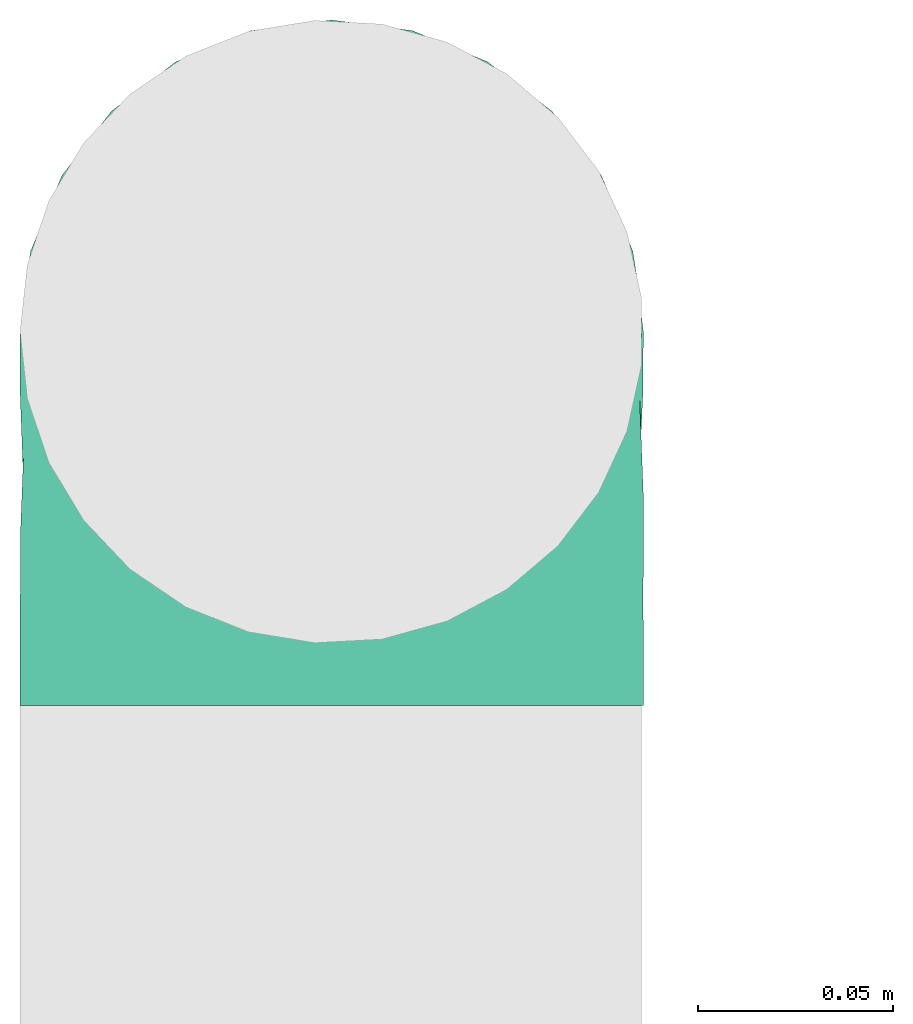
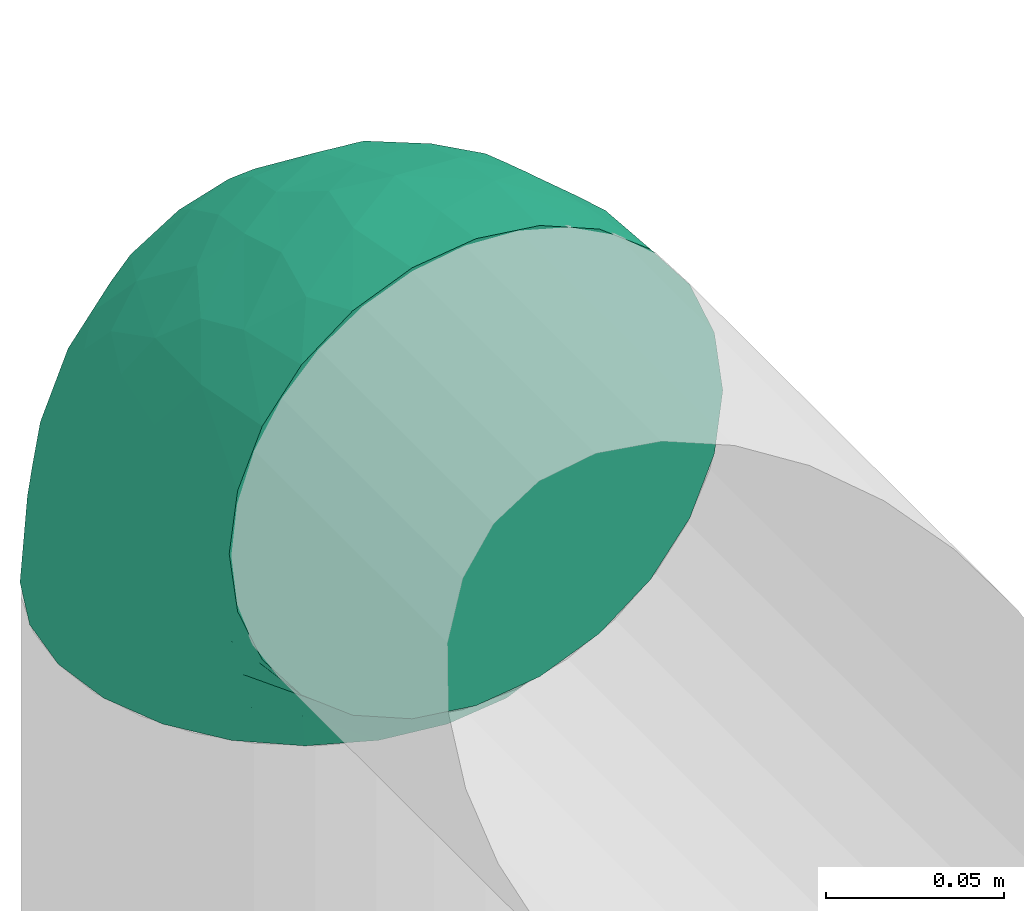
# One storey, part 10 of 12: 1 flow fitting.
"""IFC2X3 building model written with IfcOpenShell, lengths in millimetres."""

import ifcopenshell
import ifcopenshell.guid

model = None  # the IFC model being written
_history = None  # IfcOwnerHistory: only IFC2X3 demands one
_inside = {}  # id of a spatial element -> (the spatial element, [elements in it])
_under = {}  # id of a project, library or spatial element -> (it, [spatial elements below it])
_declared = {}  # id of a project -> (the project, [libraries it declares])
_typed = {}  # id of a type object -> (the type object, [elements of that type])
_made_of = {}  # id of a material, layer set ... -> (it, [elements and type objects made of it])


def new_model(schema):
    """Start an empty IFC model of exactly this schema.

    Asked for "IFC4X3", IfcOpenShell would pick the latest addendum, in which some entities
    have other attributes; the version numbers below select the first issue.
    IFC2X3 requires an IfcOwnerHistory on every rooted entity: one is made here for all.
    """
    global model, _history
    if schema == "IFC4X3":
        model = ifcopenshell.file(schema_version=(4, 3, 0, 0))
    else:
        model = ifcopenshell.file(schema=schema)
    _inside.clear()
    _under.clear()
    _declared.clear()
    _typed.clear()
    _made_of.clear()
    _history = None
    if model.schema == "IFC2X3":
        org = make("IfcOrganization", Name="unknown")
        user = make(
            "IfcPersonAndOrganization",
            ThePerson=make("IfcPerson", FamilyName="unknown"),
            TheOrganization=org,
        )
        app = make(
            "IfcApplication",
            ApplicationDeveloper=org,
            Version="unknown",
            ApplicationFullName="unknown",
            ApplicationIdentifier="unknown",
        )
        _history = make(
            "IfcOwnerHistory",
            OwningUser=user,
            OwningApplication=app,
            ChangeAction="ADDED",
            CreationDate=0,
        )
    return model


def make(cls, **values):
    """One entity of the class cls with the attributes given. An attribute that is None is left unset."""
    return model.create_entity(
        cls, **{name: value for name, value in values.items() if value is not None}
    )


def entity(cls, *values):
    """Any entity or typed value of the class cls, its attributes in the order of the schema. None: left unset."""
    e = model.create_entity(cls)
    for i, value in enumerate(values):
        if value is not None:
            e[i] = value
    return e


def rooted(cls, **values):
    """An entity with a GlobalId (a new one), such as an element, a storey or a relation."""
    return make(cls, GlobalId=ifcopenshell.guid.new(), OwnerHistory=_history, **values)


def si_unit(unit_type, name, prefix=None):
    """IfcSIUnit, for example si_unit("LENGTHUNIT", "METRE", prefix="MILLI")."""
    return make("IfcSIUnit", UnitType=unit_type, Prefix=prefix, Name=name)


def converted_unit(unit_type, name, factor, base, dimensions=None, offset=None):
    """IfcConversionBasedUnit, such as the inch: factor (a typed value) times the base unit."""
    return make(
        "IfcConversionBasedUnit"
        if offset is None
        else "IfcConversionBasedUnitWithOffset",
        ConversionOffset=offset,
        Dimensions=None
        if dimensions is None
        else entity("IfcDimensionalExponents", *dimensions),
        UnitType=unit_type,
        Name=name,
        ConversionFactor=make(
            "IfcMeasureWithUnit", ValueComponent=factor, UnitComponent=base
        ),
    )


def derived_unit(unit_type, elements):
    """IfcDerivedUnit: a product of units, each with its exponent."""
    return make(
        "IfcDerivedUnit",
        Elements=[
            make("IfcDerivedUnitElement", Unit=unit, Exponent=power)
            for unit, power in elements
        ],
        UnitType=unit_type,
    )


def assignment(units):
    """IfcUnitAssignment: the units of a project."""
    return None if units is None else make("IfcUnitAssignment", Units=units)


def point(xyz):
    """IfcCartesianPoint."""
    return None if xyz is None else make("IfcCartesianPoint", Coordinates=xyz)


def direction(xyz):
    """IfcDirection."""
    return None if xyz is None else make("IfcDirection", DirectionRatios=xyz)


def frame(location, z_axis=None, x_axis=None):
    """IfcAxis2Placement3D, a coordinate frame: its origin and axes. An axis left out is left unset."""
    return make(
        "IfcAxis2Placement3D",
        Location=point(location),
        Axis=direction(z_axis),
        RefDirection=direction(x_axis),
    )


def origin():
    """The frame at (0, 0, 0) with its axes left unset."""
    return frame((0.0, 0.0, 0.0))


def place(relative_to, where):
    """IfcLocalPlacement: puts the frame where relative to a parent placement (None: the world)."""
    return make(
        "IfcLocalPlacement", PlacementRelTo=relative_to, RelativePlacement=where
    )


def context(
    kind, dimensions, precision=None, world=None, true_north=None, identifier=None
):
    """IfcGeometricRepresentationContext, for example the 3D "Model" context."""
    return make(
        "IfcGeometricRepresentationContext",
        ContextIdentifier=identifier,
        ContextType=kind,
        CoordinateSpaceDimension=dimensions,
        Precision=precision,
        WorldCoordinateSystem=world,
        TrueNorth=true_north,
    )


def subcontext(parent, identifier, kind, view, scale=None):
    """IfcGeometricRepresentationSubContext, for example "Body" below "Model"."""
    return make(
        "IfcGeometricRepresentationSubContext",
        ContextIdentifier=identifier,
        ContextType=kind,
        ParentContext=parent,
        TargetScale=scale,
        TargetView=view,
    )


def project(units=None, contexts=None):
    """IfcProject with its units and contexts."""
    return rooted(
        "IfcProject",
        Name="project",
        RepresentationContexts=contexts,
        UnitsInContext=assignment(units),
    )


def spatial(cls, under=None, at=None, **own):
    """A site, building, storey or space (cls), placed at a placement, below another one or the project."""
    s = rooted(cls, ObjectPlacement=at, **own)
    if under is not None:
        _under.setdefault(under.id(), (under, []))[1].append(s)
    return s


def faces_of(points, faces, orient=None, outer=None):
    """IfcFace entities. A face is a list of loops; a loop is a list of indices into points, from 0.

    orient and outer hold one flag for each loop. By default every Orientation is true, the
    first loop of a face is its IfcFaceOuterBound and the others are IfcFaceBound.
    """
    made = []
    for i, loops in enumerate(faces):
        bounds = []
        for j, loop in enumerate(loops):
            is_outer = j == 0 if outer is None else outer[i][j]
            bounds.append(
                make(
                    "IfcFaceOuterBound" if is_outer else "IfcFaceBound",
                    Bound=make("IfcPolyLoop", Polygon=[points[k] for k in loop]),
                    Orientation=True if orient is None else orient[i][j],
                )
            )
        made.append(make("IfcFace", Bounds=bounds))
    return made


def faceted_brep(points, faces, orient=None, outer=None, voids=None):
    """IfcFacetedBrep: a solid bounded by flat faces; with voids (closed shells), ...WithVoids."""
    shared = [point(p) for p in points]
    hull = make("IfcClosedShell", CfsFaces=faces_of(shared, faces, orient, outer))
    if voids is None:
        return make("IfcFacetedBrep", Outer=hull)
    return make(
        "IfcFacetedBrepWithVoids",
        Outer=hull,
        Voids=[
            make(cls, CfsFaces=faces_of(shared, fs, o, b)) for cls, fs, o, b in voids
        ],
    )


def shape(context_of_items, identifier, shape_type, items):
    """IfcShapeRepresentation: the items that make up one representation, for example the "Body"."""
    return make(
        "IfcShapeRepresentation",
        ContextOfItems=context_of_items,
        RepresentationIdentifier=identifier,
        RepresentationType=shape_type,
        Items=items,
    )


def source(mapping_origin, context_of_items, identifier, shape_type, items):
    """IfcRepresentationMap: a shape defined once, which mapped items show again and again."""
    return make(
        "IfcRepresentationMap",
        MappingOrigin=mapping_origin,
        MappedRepresentation=shape(context_of_items, identifier, shape_type, items),
    )


def transform(
    local_origin,
    x_axis=None,
    y_axis=None,
    z_axis=None,
    scale=None,
    scale2=None,
    scale3=None,
    uniform=True,
):
    """IfcCartesianTransformationOperator3D, or its non-uniform kind. x_axis, y_axis, z_axis: its Axis1, 2, 3."""
    if uniform:
        return make(
            "IfcCartesianTransformationOperator3D",
            Axis1=direction(x_axis),
            Axis2=direction(y_axis),
            LocalOrigin=point(local_origin),
            Scale=scale,
            Axis3=direction(z_axis),
        )
    return make(
        "IfcCartesianTransformationOperator3DnonUniform",
        Axis1=direction(x_axis),
        Axis2=direction(y_axis),
        LocalOrigin=point(local_origin),
        Scale=scale,
        Axis3=direction(z_axis),
        Scale2=scale2,
        Scale3=scale3,
    )


def mapped(mapping_source, mapping_target):
    """IfcMappedItem: shows the shape of a source again, moved by a transform."""
    return make(
        "IfcMappedItem", MappingSource=mapping_source, MappingTarget=mapping_target
    )


def made_of(thing, what):
    """Note that an element or type object is made of a material, layer set ...; save() writes the relation."""
    if what is not None:
        _made_of.setdefault(what.id(), (what, []))[1].append(thing)
    return thing


def type_object(cls, material=None, **own):
    """A type object (cls), such as IfcWallType, which elements share."""
    return made_of(rooted(cls, **own), material)


def type_shapes(of_type, sources):
    """Give a type object the sources (RepresentationMaps) that its elements show as mapped items."""
    of_type.RepresentationMaps = sources


def element(
    cls,
    number,
    at=None,
    inside=None,
    cuts=None,
    type_object=None,
    material=None,
    context=None,
    identifier="Body",
    shape_type=None,
    held_by="IfcProductDefinitionShape",
    body=None,
    shapes=None,
    **own,
):
    """One element of the class cls, such as IfcWall. Its Tag is "e" and its number.

    at: its placement. inside: the storey or other place that contains it. cuts: it is an
    opening in that element (IfcRelVoidsElement). A single representation is given by context,
    identifier, shape_type and body (its items); several are given by shapes. held_by: the class
    of the entity that holds the representations. save() writes the other relations.
    """
    e = rooted(cls, Tag="e%d" % number, ObjectPlacement=at, **own)
    if body is not None:
        shapes = [shape(context, identifier, shape_type, body)]
    if shapes is not None:
        e.Representation = make(held_by, Representations=shapes)
    if inside is not None:
        _inside.setdefault(inside.id(), (inside, []))[1].append(e)
    if cuts is not None:
        rooted(
            "IfcRelVoidsElement", RelatingBuildingElement=cuts, RelatedOpeningElement=e
        )
    if type_object is not None:
        _typed.setdefault(type_object.id(), (type_object, []))[1].append(e)
    return made_of(e, material)


def aggregate(whole, parts):
    """IfcRelAggregates: a whole, such as a stair, and the parts it consists of."""
    return rooted("IfcRelAggregates", RelatingObject=whole, RelatedObjects=parts)


def save(model, path):
    """Write the relations noted so far, then the file.

    IfcRelAggregates (storeys below a building ...), IfcRelContainedInSpatialStructure (elements
    in a storey), IfcRelDefinesByType, IfcRelAssociatesMaterial and IfcRelDeclares: one each for
    every whole, place, type object, material and project.
    """
    for whole, parts in _under.values():
        aggregate(whole, parts)
    for where, things in _inside.values():
        rooted(
            "IfcRelContainedInSpatialStructure",
            RelatedElements=things,
            RelatingStructure=where,
        )
    for kind, things in _typed.values():
        rooted("IfcRelDefinesByType", RelatedObjects=things, RelatingType=kind)
    for what, things in _made_of.values():
        rooted("IfcRelAssociatesMaterial", RelatedObjects=things, RelatingMaterial=what)
    for by, libraries in _declared.values():
        rooted("IfcRelDeclares", RelatingContext=by, RelatedDefinitions=libraries)
    model.write(path)


model = new_model("IFC2X3")

# Units and contexts
model_context = context("Model", 3, precision=0.01, world=origin(), true_north=direction((6.12303176911189e-17, 1.0)))
body_context = subcontext(model_context, "Body", "Model", "MODEL_VIEW")
ifc_project = project(units=[si_unit("LENGTHUNIT", "METRE", prefix="MILLI"), si_unit("AREAUNIT", "SQUARE_METRE"), si_unit("VOLUMEUNIT", "CUBIC_METRE"), converted_unit("PLANEANGLEUNIT", "DEGREE", entity("IfcRatioMeasure", 0.0174532925199433), si_unit("PLANEANGLEUNIT", "RADIAN"), dimensions=[0, 0, 0, 0, 0, 0, 0]), si_unit("MASSUNIT", "GRAM", prefix="KILO"), derived_unit("MASSDENSITYUNIT", [(si_unit("MASSUNIT", "GRAM", prefix="KILO"), 1), (si_unit("LENGTHUNIT", "METRE"), -3)]), si_unit("TIMEUNIT", "SECOND"), si_unit("FREQUENCYUNIT", "HERTZ"), si_unit("THERMODYNAMICTEMPERATUREUNIT", "DEGREE_CELSIUS"), derived_unit("THERMALTRANSMITTANCEUNIT", [(si_unit("MASSUNIT", "GRAM", prefix="KILO"), 1), (si_unit("THERMODYNAMICTEMPERATUREUNIT", "KELVIN"), -1), (si_unit("TIMEUNIT", "SECOND"), -3)]), derived_unit("VOLUMETRICFLOWRATEUNIT", [(si_unit("LENGTHUNIT", "METRE"), 3), (si_unit("TIMEUNIT", "SECOND"), -1)]), si_unit("ELECTRICCURRENTUNIT", "AMPERE"), si_unit("ELECTRICVOLTAGEUNIT", "VOLT"), si_unit("POWERUNIT", "WATT"), si_unit("FORCEUNIT", "NEWTON", prefix="KILO"), si_unit("ILLUMINANCEUNIT", "LUX"), si_unit("LUMINOUSFLUXUNIT", "LUMEN"), si_unit("LUMINOUSINTENSITYUNIT", "CANDELA"), derived_unit("USERDEFINED", [(si_unit("MASSUNIT", "GRAM", prefix="KILO"), -1), (si_unit("LENGTHUNIT", "METRE"), -2), (si_unit("TIMEUNIT", "SECOND"), 3), (si_unit("LUMINOUSFLUXUNIT", "LUMEN"), 1)]), derived_unit("LINEARVELOCITYUNIT", [(si_unit("LENGTHUNIT", "METRE"), 1), (si_unit("TIMEUNIT", "SECOND"), -1)]), si_unit("PRESSUREUNIT", "PASCAL"), derived_unit("USERDEFINED", [(si_unit("LENGTHUNIT", "METRE"), -2), (si_unit("MASSUNIT", "GRAM", prefix="KILO"), 1), (si_unit("TIMEUNIT", "SECOND"), -2)])], contexts=[model_context])

# Site, building, storey
site_placement = place(None, origin())
site = spatial("IfcSite", under=ifc_project, at=site_placement, CompositionType="ELEMENT")
building_placement = place(site_placement, origin())
building = spatial("IfcBuilding", under=site, at=building_placement, CompositionType="ELEMENT")
storey_placement = place(building_placement, frame((0.0, 0.0, 4000.0)))
storey = spatial("IfcBuildingStorey", under=building, at=storey_placement, Name="01 Level", CompositionType="ELEMENT", Elevation=4000.0)

# Flow fitting
duct_fitting_type = type_object("IfcDuctFittingType", Name="Air_Elbow short_Circ", PredefinedType="NOTDEFINED")
shared_shape = source(origin(), body_context, "Body", "Brep", [
    faceted_brep([(-96.0, 0.0, -80.0), (-96.0, -20.7055236082018, -77.2740661031254), (-96.0, -40.0, -69.2820323027551), (-96.0, -56.5685424949239, -56.5685424949238), (-96.0, -69.2820323027551, -40.0), (-96.0, -77.2740661031255, -20.7055236082016), (-96.0, -80.0, 0.0), (-96.0, -77.2740661031253, 20.7055236082021), (-96.0, -69.2820323027549, 40.0), (-96.0, -56.5685424949235, 56.5685424949241), (-96.0, -40.0, 69.2820323027553), (-96.0, -30.3527618041005, 73.2780492029404), (-96.0, -20.7055236082013, 77.2740661031256), (-96.0, 0.0, 80.0), (-96.0, 20.705523608202, 77.2740661031254), (-96.0, 40.0, 69.2820323027549), (-96.0, 56.568542494924, 56.5685424949236), (-96.0, 69.2820323027553, 40.0), (-96.0, 77.2740661031256, 20.7055236082014), (-96.0, 80.0, 0.0), (-96.0, 77.2740661031254, -20.7055236082019), (-96.0, 69.282032302755, -40.0), (-96.0, 56.5685424949237, -56.5685424949239), (-96.0, 40.0, -69.2820323027552), (-96.0, 20.7055236082015, -77.2740661031255), (0.0, -96.0, -80.0), (20.7055236082025, -96.0, -77.2740661031255), (40.0, -96.0, -69.2820323027552), (56.5685424949246, -96.0, -56.5685424949239), (69.2820323027559, -96.0, -40.0), (77.2740661031264, -96.0, -20.7055236082019), (80.0, -96.0, 0.0), (77.2740661031265, -96.0, 20.7055236082014), (69.2820323027562, -96.0, 40.0), (56.5685424949249, -96.0, 56.5685424949236), (40.0, -96.0, 69.2820323027549), (20.7055236082029, -96.0, 77.2740661031254), (0.0, -96.0, 80.0), (-20.7055236082004, -96.0, 77.2740661031256), (-40.0, -96.0, 69.2820323027553), (-56.5685424949226, -96.0, 56.5685424949241), (-69.2820323027539, -96.0, 40.0), (-77.2740661031244, -96.0, 20.7055236082021), (-80.0, -96.0, 0.0), (-77.2740661031245, -96.0, -20.7055236082016), (-69.2820323027542, -96.0, -40.0), (-56.5685424949229, -96.0, -56.5685424949238), (-40.0, -96.0, -69.2820323027551), (-30.3527618041, -96.0, -73.2780492029402), (-20.7055236082008, -96.0, -77.2740661031254), (-69.6571465232348, -6.28172173912476, 79.9611058756859), (-66.7862289407348, 74.1387210661139, 22.9795507758541), (-78.4902527850466, 65.2482264041437, 44.9229732355936), (-55.1380888291464, 64.4450584799279, 39.5029426177976), (-75.1250134759213, -46.3506195730757, 68.0011973810265), (-79.9123689128389, -22.4151301859584, 77.2816866630488), (-67.1316735243184, 51.7530432423058, 58.5204707533666), (-62.9760666105318, 34.5362195419601, 70.0448030595901), (-46.2820694578435, 43.7397705581167, 60.5188244193914), (-76.2276812833835, 77.3969248578635, 0.0), (-50.4478480619551, 74.0029454268759, 0.0), (-6.30632028234235, -70.6421404093778, 79.9513108199466), (-27.189372084162, -68.980536479128, 76.8941402015288), (-29.8609237116382, 28.9682345099716, 65.8760199345924), (-47.7584488981354, 13.6212410427434, 76.3881123659885), (43.7397637815864, -46.2820598522933, 60.518827155348), (51.7530435574228, -67.1316742002235, 58.5204705859065), (57.6005967886466, -33.4719572927763, 39.0176496769077), (-74.2591571701267, 14.3645886695287, 78.2829835259588), (7.8513563843086, 42.4938374080907, 21.3232874317503), (23.3846344985257, 27.9066135199674, 24.7887114209846), (28.4507934888335, 28.4507934888321, 0.0), (-84.190871651952, -70.905997349447, 41.7100461919055), (10.21505333872, 32.0754161621096, 38.020212353501), (-0.0180155578363953, 25.9284255475521, 53.836744023285), (24.7272484782103, 2.06889411058577, 53.4325037134459), (-41.7574890626937, -15.123136403511, 79.988056483004), (-64.5619855594544, -27.52018553659, 77.2892967298799), (-8.0, 56.420471066061, 0.0), (-29.2239240309769, 65.2117082464685, 0.0), (-24.5336756868846, 60.9669573051438, 23.5003835585885), (-16.4008295437786, -51.3122057461681, 79.8609584412684), (-84.6862915010143, -84.6862915010152, 0.0), (-83.0529092063249, -83.0529092103045, 19.0855009657076), (-82.4185651555764, -62.2587017800419, 53.3339952483838), (-46.3022193149449, -75.902750025661, 67.8445262622594), (-9.5260688639158, 47.7232209131232, 35.4187162694583), (74.1387213421635, -66.7862279048973, 22.9795492840646), (34.536215572589, -62.976064096567, 70.0448048426748), (14.3645870599314, -74.259154996167, 78.2829837700474), (65.2482273833467, -78.4902510979302, 44.9229715327465), (-25.6317751341749, -1.2640655514879, 76.9124052095498), (-12.3935655196116, -25.4017250572252, 78.8652642576962), (60.9669574479924, -24.5336725945725, 23.5003789659965), (64.4450597015273, -55.1380839274934, 39.5029384026545), (69.8186739706361, -42.5625104806759, 16.7980672722629), (77.3969247188647, -76.2276802275763, 0.0), (74.002945426877, -50.4478480619565, 0.0), (-52.4774893100348, -53.0631556360015, 72.0041598972686), (-66.5995156060253, -66.5995146556305, 58.6370817132137), (-76.4857465466113, -78.9385356944492, 38.5867538667356), (-62.2587016209511, -82.4185645906685, 53.3339956492136), (13.6212369177471, -47.7584433090926, 76.3881128402526), (28.9682276847195, -29.8609133580269, 65.8760207540895), (-6.49930484510329, 53.7890406240985, 15.4645725223014), (-33.731289034344, -40.0214486160993, 79.0537019298314), (46.1336936566893, -26.2441492635858, 50.151541479116), (50.0005984633279, -1.26038287501495, 17.5763945268078), (56.4204710660622, -8.0, 0.0), (42.4356322774479, 10.225396744416, 0.0), (-45.4536887619888, 68.8356359385787, 23.6914879663761), (-33.3493864711472, 57.4572215948989, 39.1720709545353), (35.9683398342664, 11.0724559744972, 30.5391080332169), (-26.2441652621668, 46.1336984778153, 50.1515448602929), (36.6749123583047, 17.5982116941791, 14.5644188861001), (65.2117082464696, -29.2239240309784, 0.0), (49.5968730216335, -12.1440064858134, 34.8325942562253), (-47.1533280807863, -29.0746114834461, 78.9127210009486), (-0.981722938535007, -51.3162880079176, 79.4920802366619), (-1.95170750213435, -1.95169859379814, 70.9272590604952), (12.4951682569875, -20.0804783439543, 71.2292489374933), (13.0725391330592, -1.13338064801589, 63.5790506070627), (-1.93327092594732, 13.4823821925323, 63.7412032706882), (-18.9298205951927, 13.0048872663631, 70.6672094580024), (10.2253967444173, 42.4356322774466, 0.0), (-68.9805369123341, -27.1893702897943, -76.8941406355589), (-46.3506180288022, -75.1250185023919, -68.0011970559212), (-27.5201921618733, -64.5619784506715, -77.2892959136582), (-22.4151342180024, -79.9123577737124, -77.2816862456941), (-74.2591561090454, 14.364589592643, -78.2829832920378), (-66.78622820047, 74.1387209331735, -22.9795507950237), (-42.5625109127564, 69.8186736490614, -16.7980693145318), (-70.6421421271429, -6.30631801763141, -79.9513108797024), (-1.2640784754681, -25.6317655571971, -76.9124065444174), (-15.1231475192353, -41.7574898106582, -79.9880566497423), (-25.401718902627, -12.3935649209934, -78.8652635038296), (-82.4185656924104, -62.258701559575, -53.3339952529289), (-66.5995166501766, -66.5995137008527, -58.6370816545605), (-78.9385361639639, -76.4857467527193, -38.5867530236755), (53.7890400497189, -6.49930371043273, -15.4645720709197), (60.9669567069012, -24.5336743104721, -23.5003834743896), (-24.5336751436549, 60.9669572920351, -23.5003828649414), (-55.1380878256228, 64.4450583029017, -39.5029424837467), (-46.2820677406335, 43.7397707662098, -60.5188237522514), (-26.2441631797834, 46.1336980827234, -50.1515441608816), (-29.8609212227281, 28.9682353164184, -65.8760186412515), (74.1387206827049, -66.7862275406284, -22.9795512458422), (-40.0214489824224, -33.7312845774564, -79.0537024061946), (-78.4902524468744, 65.2482264004152, -44.9229731872606), (-75.902751427461, -46.3022186029078, -67.8445263463497), (-70.9059970555813, -84.1908706304995, -41.7100473389448), (-62.9760652707231, 34.536220162299, -70.044802546446), (-67.1316724627346, 51.7530434014037, -58.5204704180807), (-33.4719630839568, 57.6005950429912, -39.0176564793206), (-51.3122062597491, -16.4008248291117, -79.8609586691244), (-6.28171714934502, -69.65712797409, -79.9611061760713), (51.7530427306645, -67.1316703492073, -58.5204706539109), (-83.0529092397056, -83.0529091932979, -19.0855009185769), (68.8356349913375, -45.45368838847, -23.6914905340598), (-62.258701383479, -82.4185638376438, -53.3339962098694), (34.53621889603, -62.9760621802168, -70.0448028055675), (-1.26038544288408, 50.0005998980998, -17.5763953891677), (14.3645887716112, -74.2591526334116, -78.2829833202131), (13.6212385978137, -47.75844096294, -76.3881120677864), (65.2482261461557, -78.4902526871683, -44.9229735979605), (32.0754071702863, 10.2150656939878, -38.0202105656364), (25.9284207554091, -0.0180077987247146, -53.8367428868672), (2.068884460932, 24.7272580800759, -53.4325021883878), (47.723215348146, -9.52606271707191, -35.4187195087105), (42.4938359077841, 7.8513587520169, -21.3232866357369), (27.9066094773716, 23.3846413342612, -24.7887058003424), (28.9682309044935, -29.8609168472814, -65.8760199178674), (64.4450577206072, -55.1380878066959, -39.5029434692504), (-53.063150048133, -52.4774843719861, -72.0041634993662), (43.7397687897612, -46.2820667462245, -60.5188250739327), (-47.7584463040963, 13.6212426330217, -76.3881115880261), (57.4572201066452, -33.3493827160302, -39.1720708806551), (11.0724494499294, 35.9683446288498, -30.5391089716619), (46.1336964749623, -26.2441642243134, -50.1515465265606), (17.5982028158329, 36.6749194460897, -14.5644209948051), (-12.1440097531109, 49.5968729214507, -34.8325978072281), (-29.0746218055845, -47.1533256390974, -78.912719851915), (-51.3162911259858, -0.981717610547608, -79.4920798409907), (-1.95170139871169, -1.95169735730944, -70.9272563527003), (-20.0804667507281, 12.4951842966219, -71.2292388196267), (-1.13337124471279, 13.072540998247, -63.5790448193562), (13.4823844636247, -1.93327501577089, -63.7412039856557), (13.0048800657406, -18.9298191902065, -70.6672121474654)], [[[0, 1, 2, 3, 4, 5, 6, 7, 8, 9, 10, 11, 12, 13, 14, 15, 16, 17, 18, 19, 20, 21, 22, 23, 24]], [[25, 26, 27, 28, 29, 30, 31, 32, 33, 34, 35, 36, 37, 38, 39, 40, 41, 42, 43, 44, 45, 46, 47, 48, 49]], [[50, 13, 12]], [[51, 52, 53]], [[10, 54, 55]], [[56, 57, 58]], [[59, 51, 60]], [[61, 62, 38]], [[63, 57, 64]], [[65, 66, 67]], [[17, 16, 52]], [[15, 57, 56]], [[14, 13, 68]], [[69, 70, 71]], [[8, 7, 72]], [[68, 64, 57]], [[73, 74, 75]], [[76, 50, 77]], [[57, 15, 14]], [[9, 54, 10]], [[55, 12, 11, 10]], [[78, 79, 80]], [[62, 61, 81]], [[82, 83, 6]], [[63, 58, 57]], [[83, 7, 6]], [[8, 72, 84]], [[56, 16, 15]], [[84, 9, 8]], [[62, 85, 39]], [[86, 74, 73]], [[59, 18, 51]], [[18, 17, 51]], [[32, 87, 33]], [[35, 34, 66]], [[36, 88, 89]], [[90, 34, 33]], [[88, 36, 35]], [[91, 76, 92]], [[90, 33, 87]], [[93, 94, 95]], [[35, 66, 88]], [[32, 96, 87]], [[85, 40, 39]], [[87, 97, 95]], [[98, 99, 85]], [[41, 100, 42]], [[42, 100, 83]], [[101, 99, 100]], [[102, 88, 103]], [[43, 83, 82]], [[104, 78, 80]], [[38, 62, 39]], [[98, 85, 62]], [[92, 76, 105]], [[65, 106, 103]], [[101, 41, 40]], [[37, 61, 38]], [[107, 108, 109]], [[51, 53, 110]], [[37, 36, 89]], [[79, 110, 80]], [[110, 79, 60]], [[111, 110, 53]], [[112, 70, 73]], [[113, 86, 111]], [[71, 114, 109]], [[75, 103, 106]], [[93, 95, 115]], [[37, 89, 61]], [[108, 93, 115]], [[67, 93, 116]], [[107, 116, 93]], [[13, 50, 68]], [[117, 76, 77]], [[98, 117, 77]], [[99, 54, 84]], [[40, 85, 101]], [[98, 54, 99]], [[105, 62, 81]], [[89, 118, 61]], [[88, 66, 65]], [[94, 66, 90]], [[16, 56, 52]], [[111, 53, 56]], [[76, 64, 50]], [[64, 76, 91]], [[119, 92, 120]], [[61, 118, 81]], [[120, 121, 119]], [[116, 112, 75]], [[121, 122, 119]], [[119, 122, 123]], [[113, 63, 74]], [[119, 123, 91]], [[86, 113, 74]], [[122, 121, 75]], [[54, 98, 77]], [[105, 98, 62]], [[59, 19, 18]], [[97, 87, 96]], [[32, 31, 96]], [[102, 89, 88]], [[14, 68, 57]], [[64, 68, 50]], [[41, 101, 100]], [[99, 101, 85]], [[9, 84, 54]], [[100, 99, 72]], [[81, 92, 105]], [[102, 92, 118]], [[81, 118, 92]], [[102, 118, 89]], [[84, 72, 99]], [[83, 100, 72]], [[72, 7, 83]], [[42, 83, 43]], [[17, 52, 51]], [[53, 52, 56]], [[34, 90, 66]], [[94, 90, 87]], [[55, 54, 77]], [[55, 50, 12]], [[55, 77, 50]], [[60, 51, 110]], [[80, 110, 111]], [[86, 104, 80]], [[58, 113, 111]], [[111, 86, 80]], [[73, 69, 86]], [[69, 73, 70]], [[112, 73, 75]], [[69, 124, 104]], [[108, 107, 93]], [[112, 114, 70]], [[93, 67, 94]], [[112, 107, 114]], [[70, 114, 71]], [[109, 114, 107]], [[106, 116, 75]], [[116, 107, 112]], [[94, 67, 66]], [[67, 116, 106]], [[115, 95, 97]], [[69, 104, 86]], [[78, 104, 124]], [[69, 71, 124]], [[87, 95, 94]], [[88, 65, 103]], [[106, 65, 67]], [[56, 58, 111]], [[113, 58, 63]], [[117, 105, 76]], [[105, 117, 98]], [[63, 64, 123]], [[119, 91, 92]], [[91, 123, 64]], [[74, 63, 122]], [[123, 122, 63]], [[74, 122, 75]], [[121, 103, 75]], [[103, 121, 120]], [[120, 102, 103]], [[102, 120, 92]], [[1, 125, 2]], [[126, 127, 128]], [[129, 0, 24]], [[130, 60, 131]], [[0, 132, 1]], [[133, 134, 135]], [[136, 137, 138]], [[139, 108, 140]], [[3, 136, 4]], [[141, 142, 131]], [[138, 5, 4]], [[143, 144, 145]], [[30, 29, 146]], [[135, 134, 147]], [[148, 21, 130]], [[149, 3, 2]], [[20, 59, 130]], [[45, 44, 150]], [[151, 23, 152]], [[143, 152, 153]], [[152, 23, 22]], [[151, 24, 23]], [[125, 132, 154]], [[21, 148, 22]], [[155, 25, 49]], [[151, 129, 24]], [[20, 130, 21]], [[156, 28, 27]], [[157, 82, 6]], [[115, 158, 140]], [[157, 44, 43]], [[5, 138, 157]], [[150, 159, 45]], [[160, 27, 26]], [[161, 78, 124]], [[45, 159, 46]], [[128, 49, 48, 47]], [[2, 125, 149]], [[134, 155, 127]], [[162, 163, 160]], [[29, 28, 164]], [[126, 47, 46]], [[165, 166, 167]], [[25, 162, 26]], [[166, 165, 168]], [[132, 125, 1]], [[108, 115, 140]], [[169, 170, 71]], [[171, 160, 163]], [[27, 160, 156]], [[146, 164, 172]], [[173, 137, 149]], [[97, 96, 146]], [[171, 174, 160]], [[175, 151, 145]], [[160, 174, 156]], [[173, 149, 125]], [[47, 126, 128]], [[158, 115, 97]], [[6, 5, 157]], [[146, 172, 158]], [[96, 30, 146]], [[176, 158, 172]], [[177, 170, 165]], [[178, 168, 176]], [[71, 179, 124]], [[167, 145, 144]], [[141, 131, 79]], [[96, 31, 30]], [[78, 141, 79]], [[153, 141, 180]], [[161, 180, 141]], [[25, 155, 162]], [[147, 134, 181]], [[173, 181, 127]], [[137, 126, 159]], [[3, 149, 136]], [[173, 126, 137]], [[147, 125, 154]], [[129, 182, 132]], [[151, 152, 143]], [[142, 152, 148]], [[28, 156, 164]], [[176, 172, 156]], [[134, 163, 155]], [[163, 134, 133]], [[183, 135, 184]], [[132, 182, 154]], [[184, 185, 183]], [[180, 177, 167]], [[185, 186, 183]], [[183, 186, 187]], [[178, 171, 166]], [[183, 187, 133]], [[168, 178, 166]], [[186, 185, 167]], [[126, 173, 127]], [[147, 173, 125]], [[60, 130, 59]], [[20, 19, 59]], [[0, 129, 132]], [[175, 129, 151]], [[26, 162, 160]], [[163, 162, 155]], [[4, 136, 138]], [[137, 136, 149]], [[46, 159, 126]], [[138, 137, 150]], [[154, 135, 147]], [[175, 135, 182]], [[154, 182, 135]], [[175, 182, 129]], [[159, 150, 137]], [[157, 138, 150]], [[82, 157, 43]], [[150, 44, 157]], [[29, 164, 146]], [[172, 164, 156]], [[22, 148, 152]], [[142, 148, 130]], [[155, 128, 127]], [[128, 155, 49]], [[97, 146, 158]], [[140, 158, 176]], [[168, 139, 140]], [[174, 178, 176]], [[176, 168, 140]], [[165, 169, 168]], [[169, 165, 170]], [[177, 165, 167]], [[169, 109, 139]], [[78, 161, 141]], [[177, 179, 170]], [[141, 153, 142]], [[177, 161, 179]], [[170, 179, 71]], [[124, 179, 161]], [[144, 180, 167]], [[180, 161, 177]], [[142, 153, 152]], [[153, 180, 144]], [[79, 131, 60]], [[169, 139, 168]], [[108, 139, 109]], [[169, 71, 109]], [[130, 131, 142]], [[151, 143, 145]], [[144, 143, 153]], [[156, 174, 176]], [[178, 174, 171]], [[147, 181, 173]], [[181, 134, 127]], [[171, 163, 187]], [[183, 133, 135]], [[133, 187, 163]], [[166, 171, 186]], [[187, 186, 171]], [[166, 186, 167]], [[185, 145, 167]], [[145, 185, 184]], [[184, 175, 145]], [[175, 184, 135]]]),
])
type_shapes(duct_fitting_type, [shared_shape])
flow_fitting_placement = place(storey_placement, frame((22191.748982204, -67076.2395851399, 3000.0), z_axis=(-1.0, 0.0, 0.0), x_axis=(0.0, 0.0, 1.0)))
element("IfcFlowFitting", 1, at=flow_fitting_placement, inside=storey, type_object=duct_fitting_type, Name="elbow_short_001:Air_Elbow short_Circ", ObjectType="elbow_short_001:Air_Elbow short_Circ", context=body_context, shape_type="MappedRepresentation", body=[
    mapped(shared_shape, transform((0.0, 0.0, 0.0), scale=1.0)),
])

save(model, "model.ifc")
